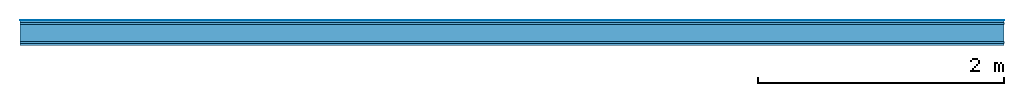
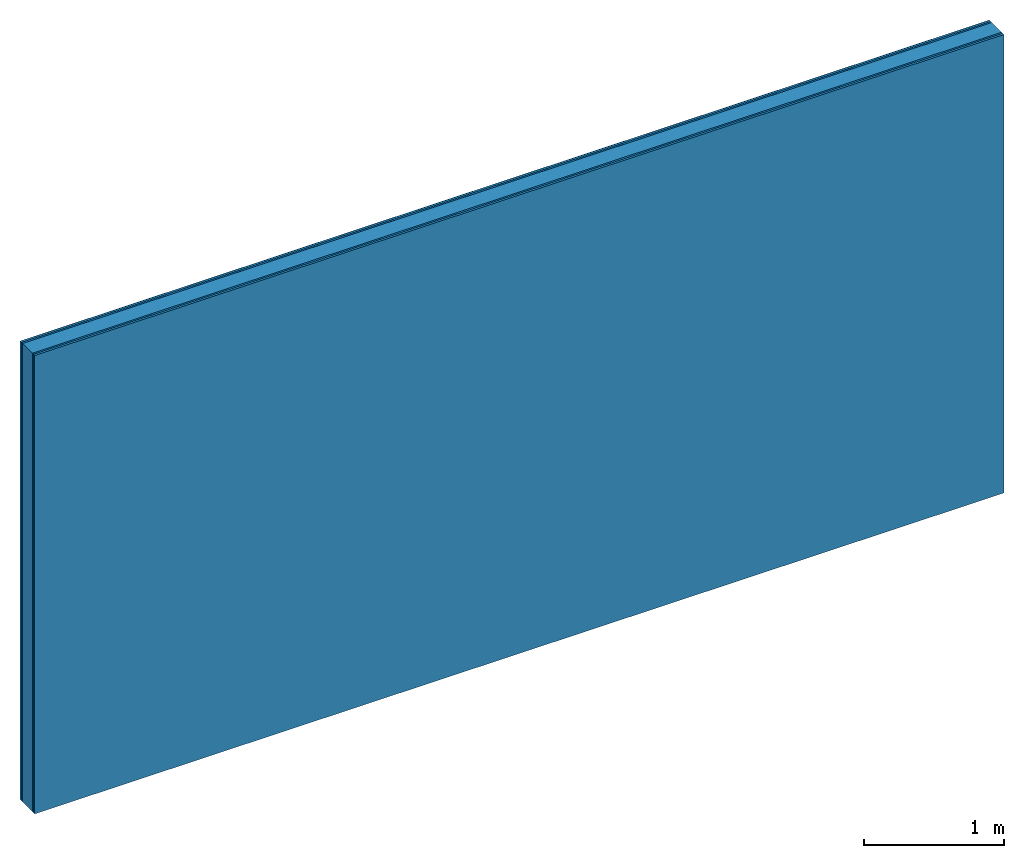
# One storey: 5 plates, 1 member, 1 element without a shape of its own.
"""IFC4 building model written with IfcOpenShell, lengths in metres."""

from ifc_helpers import new_model, si_unit, derived_unit, direction, frame, frame_2d, origin, origin_with_axes, place, context, project, spatial, rectangle, extrude, material, layer, layer_set, type_object, element, aggregate, save


model = new_model("IFC4")

# Units and contexts
plan_context = context("Plan", 3, precision=1e-05, world=origin(), true_north=direction((0.0, 1.0)))
model_context = context("Model", 3, precision=1e-05, world=origin(), true_north=direction((0.0, 1.0)))
ifc_project = project(units=[si_unit("LENGTHUNIT", "METRE"), derived_unit("SOUNDPRESSUREUNIT", [(si_unit("PRESSUREUNIT", "PASCAL", prefix="MICRO"), 0)]), si_unit("ENERGYUNIT", "JOULE", prefix="MEGA"), si_unit("MASSUNIT", "GRAM", prefix="KILO"), derived_unit("THERMALTRANSMITTANCEUNIT", [(si_unit("POWERUNIT", "WATT"), 1), (si_unit("AREAUNIT", "SQUARE_METRE"), -1), (si_unit("THERMODYNAMICTEMPERATUREUNIT", "KELVIN"), -1)]), derived_unit("AREADENSITYUNIT", [(si_unit("MASSUNIT", "GRAM", prefix="KILO"), 1), (si_unit("AREAUNIT", "SQUARE_METRE"), -1)]), derived_unit("USERDEFINED", [(si_unit("ENERGYUNIT", "JOULE", prefix="MEGA"), 1), (si_unit("AREAUNIT", "SQUARE_METRE"), -1)])], contexts=[plan_context, model_context])

# Site, building, storey
site = spatial("IfcSite", under=ifc_project)
building_placement = place(None, origin())
building = spatial("IfcBuilding", under=site, at=building_placement)
storey_placement = place(building_placement, origin())
storey = spatial("IfcBuildingStorey", under=building, at=storey_placement)

# Wall, member, plates
ifc_material_1 = material(Category="04.001")
ifc_layer_1 = layer(ifc_material_1, 0.003, Name="Surface")
ifc_material_2 = material(Category="03.007")
ifc_layer_2 = layer(ifc_material_2, 0.018, Name="2nd layer")
ifc_layer_3 = layer(ifc_material_2, 0.015, Name="1st layer")
ifc_material_3 = material(Name="of the art")
ifc_layer_4 = layer(ifc_material_3, 0.0, Name="Bond")
ifc_layer_5 = layer(None, 0.14, Name="Support")
ifc_layer_6 = layer(ifc_material_3, 0.0, Name="Bond")
ifc_layer_7 = layer(ifc_material_2, 0.015, Name="1st layer")
ifc_layer_8 = layer(ifc_material_2, 0.018, Name="2nd layer")
ifc_layer_set = layer_set([ifc_layer_1, ifc_layer_2, ifc_layer_3, ifc_layer_4, ifc_layer_5, ifc_layer_6, ifc_layer_7, ifc_layer_8])
wall_type = type_object("IfcWallType", Name="C0435", PredefinedType="NOTDEFINED", material=ifc_layer_set)
wall_placement = place(None, frame((0.0, 0.0, 0.0), z_axis=(0.0, -1.0, 0.0), x_axis=(1.0, 0.0, 0.0)))
wall = element("IfcWall", 1, at=wall_placement, inside=storey, type_object=wall_type, material=ifc_layer_set, Name="Wall #1")
ifc_material_4 = material(Name="Solid timber panel")
member_placement = place(wall_placement, origin())
member = element("IfcMember", 2, at=member_placement, material=ifc_material_4, Name="Support", context=plan_context, shape_type="SweptSolid", body=[
    extrude(rectangle(XDim=1.0, YDim=0.14, at=frame_2d((0.5, 0.07), x_axis=(1.0, 0.0))), frame((0.0, 4.0, 0.036), z_axis=(0.0, -1.0, 0.0), x_axis=(1.0, 0.0, 0.0)), (0.0, 0.0, 1.0), 4.0),
    extrude(rectangle(XDim=1.0, YDim=0.14, at=frame_2d((0.5, 0.07), x_axis=(1.0, 0.0))), frame((1.0, 4.0, 0.036), z_axis=(0.0, -1.0, 0.0), x_axis=(1.0, 0.0, 0.0)), (0.0, 0.0, 1.0), 4.0),
    extrude(rectangle(XDim=1.0, YDim=0.14, at=frame_2d((0.5, 0.07), x_axis=(1.0, 0.0))), frame((2.0, 4.0, 0.036), z_axis=(0.0, -1.0, 0.0), x_axis=(1.0, 0.0, 0.0)), (0.0, 0.0, 1.0), 4.0),
    extrude(rectangle(XDim=1.0, YDim=0.14, at=frame_2d((0.5, 0.07), x_axis=(1.0, 0.0))), frame((3.0, 4.0, 0.036), z_axis=(0.0, -1.0, 0.0), x_axis=(1.0, 0.0, 0.0)), (0.0, 0.0, 1.0), 4.0),
    extrude(rectangle(XDim=1.0, YDim=0.14, at=frame_2d((0.5, 0.07), x_axis=(1.0, 0.0))), frame((4.0, 4.0, 0.036), z_axis=(0.0, -1.0, 0.0), x_axis=(1.0, 0.0, 0.0)), (0.0, 0.0, 1.0), 4.0),
    extrude(rectangle(XDim=1.0, YDim=0.14, at=frame_2d((0.5, 0.07), x_axis=(1.0, 0.0))), frame((5.0, 4.0, 0.036), z_axis=(0.0, -1.0, 0.0), x_axis=(1.0, 0.0, 0.0)), (0.0, 0.0, 1.0), 4.0),
    extrude(rectangle(XDim=1.0, YDim=0.14, at=frame_2d((0.5, 0.07), x_axis=(1.0, 0.0))), frame((6.0, 4.0, 0.036), z_axis=(0.0, -1.0, 0.0), x_axis=(1.0, 0.0, 0.0)), (0.0, 0.0, 1.0), 4.0),
    extrude(rectangle(XDim=1.0, YDim=0.14, at=frame_2d((0.5, 0.07), x_axis=(1.0, 0.0))), frame((7.0, 4.0, 0.036), z_axis=(0.0, -1.0, 0.0), x_axis=(1.0, 0.0, 0.0)), (0.0, 0.0, 1.0), 4.0),
])
plate_1_placement = place(wall_placement, origin())
plate_1 = element("IfcPlate", 3, at=plate_1_placement, material=ifc_material_1, Name="Surface", context=plan_context, shape_type="SweptSolid", body=[
    extrude(rectangle(XDim=8.0, YDim=4.0, at=frame_2d((4.0, 2.0), x_axis=(1.0, 0.0))), origin_with_axes(), (0.0, 0.0, 1.0), 0.003),
])
plate_2_placement = place(wall_placement, origin())
plate_2 = element("IfcPlate", 4, at=plate_2_placement, material=ifc_material_2, Name="2nd layer", context=plan_context, shape_type="SweptSolid", body=[
    extrude(rectangle(XDim=8.0, YDim=4.0, at=frame_2d((4.0, 2.0), x_axis=(1.0, 0.0))), frame((0.0, 0.0, 0.003), z_axis=(0.0, 0.0, 1.0), x_axis=(1.0, 0.0, 0.0)), (0.0, 0.0, 1.0), 0.018),
])
plate_3_placement = place(wall_placement, origin())
plate_3 = element("IfcPlate", 5, at=plate_3_placement, material=ifc_material_2, Name="1st layer", context=plan_context, shape_type="SweptSolid", body=[
    extrude(rectangle(XDim=8.0, YDim=4.0, at=frame_2d((4.0, 2.0), x_axis=(1.0, 0.0))), frame((0.0, 0.0, 0.021), z_axis=(0.0, 0.0, 1.0), x_axis=(1.0, 0.0, 0.0)), (0.0, 0.0, 1.0), 0.015),
])
plate_4_placement = place(wall_placement, origin())
plate_4 = element("IfcPlate", 6, at=plate_4_placement, material=ifc_material_2, Name="1st layer", context=plan_context, shape_type="SweptSolid", body=[
    extrude(rectangle(XDim=8.0, YDim=4.0, at=frame_2d((4.0, 2.0), x_axis=(1.0, 0.0))), frame((0.0, 0.0, 0.176), z_axis=(0.0, 0.0, 1.0), x_axis=(1.0, 0.0, 0.0)), (0.0, 0.0, 1.0), 0.015),
])
plate_5_placement = place(wall_placement, origin())
plate_5 = element("IfcPlate", 7, at=plate_5_placement, material=ifc_material_2, Name="2nd layer", context=plan_context, shape_type="SweptSolid", body=[
    extrude(rectangle(XDim=8.0, YDim=4.0, at=frame_2d((4.0, 2.0), x_axis=(1.0, 0.0))), frame((0.0, 0.0, 0.191), z_axis=(0.0, 0.0, 1.0), x_axis=(1.0, 0.0, 0.0)), (0.0, 0.0, 1.0), 0.018),
])
aggregate(wall, [plate_1, plate_2, plate_3, member, plate_4, plate_5])

save(model, "model.ifc")
